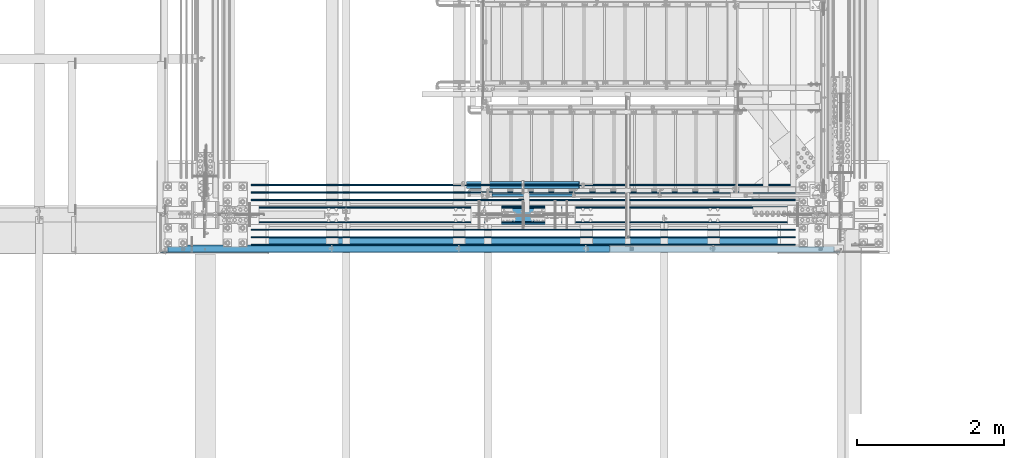
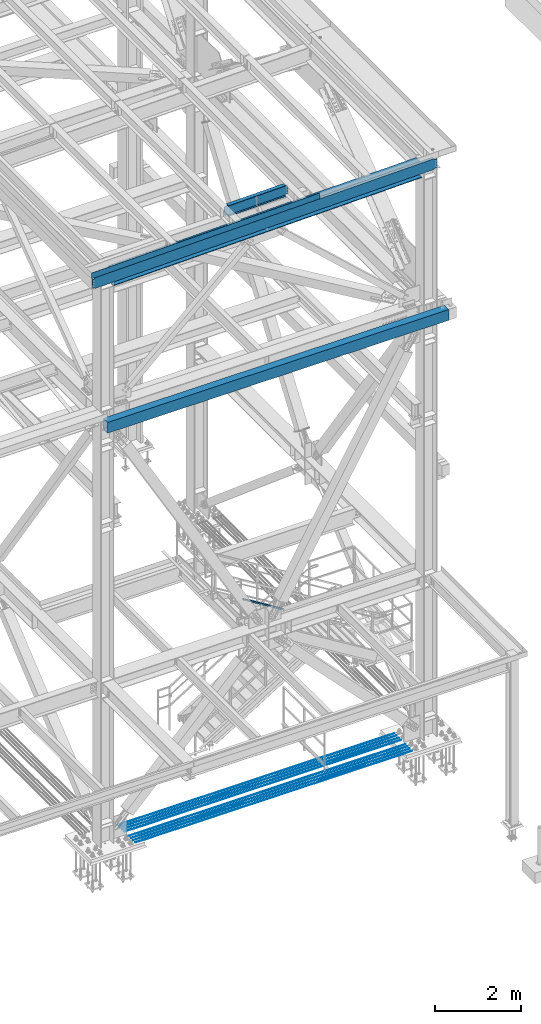
# One storey, part 1941 of 3843: 13 beams, 1 member, 13 elements without a shape of their own.
"""IFC2X3 building model written with IfcOpenShell, lengths in millimetres."""

from ifc_helpers import new_model, si_unit, frame, origin_with_axes, place, context, subcontext, project, spatial, faceted_brep, material, type_object, element, aggregate, save


model = new_model("IFC2X3")

# Units and contexts
model_context = context("Model", 3, precision=1e-05, world=origin_with_axes())
body_context = subcontext(model_context, "Body", "Model", "MODEL_VIEW")
ifc_project = project(units=[si_unit("LENGTHUNIT", "METRE", prefix="MILLI"), si_unit("AREAUNIT", "SQUARE_METRE"), si_unit("VOLUMEUNIT", "CUBIC_METRE"), si_unit("MASSUNIT", "GRAM", prefix="KILO"), si_unit("TIMEUNIT", "SECOND"), si_unit("PLANEANGLEUNIT", "RADIAN"), si_unit("SOLIDANGLEUNIT", "STERADIAN"), si_unit("THERMODYNAMICTEMPERATUREUNIT", "DEGREE_CELSIUS"), si_unit("LUMINOUSINTENSITYUNIT", "LUMEN")], contexts=[model_context])

# Site, building, storey
site_placement = place(None, origin_with_axes())
site = spatial("IfcSite", under=ifc_project, at=site_placement, CompositionType="ELEMENT")
building_placement = place(site_placement, origin_with_axes())
building = spatial("IfcBuilding", under=site, at=building_placement, Name="Undefined", CompositionType="ELEMENT")
storey_placement = place(building_placement, origin_with_axes())
storey = spatial("IfcBuildingStorey", under=building, at=storey_placement, Name="Undefined", CompositionType="ELEMENT", Elevation=0.0)

# Assembly, member
assembly_1_placement = place(storey_placement, origin_with_axes())
assembly_1 = element("IfcElementAssembly", 1, at=assembly_1_placement, inside=storey, Name="RAIL", AssemblyPlace="NOTDEFINED", PredefinedType="RIGID_FRAME")
ifc_material_1 = material()
member_type = type_object("IfcMemberType", Name="HSS1-1/2X1-1/2X1/4", PredefinedType="NOTDEFINED")
member_placement = place(assembly_1_placement, frame((82016.6000000184, 15265.4, 34796.0461536349), z_axis=(0.524097425775922, 0.0, 0.851658316635875), x_axis=(-0.851658316635873, 0.0, 0.524097425775925)))
member = element("IfcMember", 2, at=member_placement, type_object=member_type, material=ifc_material_1, Name="RAIL", ObjectType="HSS1-1/2X1-1/2X1/4", context=body_context, shape_type="Brep", body=[
    faceted_brep([(14.5527402998268, 12.6999993300014, -12.6999993299833), (14.5527402998268, -12.6999993300014, -12.6999993299833), (1308.66871958042, -12.6999993299996, -12.6999993292702), (1308.66871958042, 12.6999993299996, -12.6999993292702), (30.1835087105574, -12.6999993300014, 12.6999993299978), (1315.85799084432, -12.6999993299996, 12.6999993306963), (30.1835087105574, 12.6999993300014, 12.6999993299978), (1315.85799084432, 12.6999993299996, 12.6999993306963), (10.6450480494532, 19.0499992350015, -19.0499992349796), (34.091200960931, 19.0499992350015, 19.0499992349942), (1317.65530872822, 19.0499992349996, 19.0499992356781), (1306.87140169651, 19.0499992349996, -19.0499992342811), (34.091200960931, -19.0499992350015, 19.0499992349942), (1317.65530872822, -19.0499992349996, 19.0499992356781), (10.6450480494532, -19.0499992350015, -19.0499992349796), (1306.87140169651, -19.0499992349996, -19.0499992342811)], [[[0, 1, 2, 3]], [[1, 4, 5, 2]], [[4, 6, 7, 5]], [[6, 0, 3, 7]], [[8, 9, 10, 11]], [[9, 12, 13, 10]], [[12, 14, 15, 13]], [[14, 8, 11, 15]], [[13, 15, 11, 10], [5, 7, 3, 2]], [[14, 12, 9, 8], [6, 4, 1, 0]]]),
])
aggregate(assembly_1, [member])

# Assembly, beam
assembly_2_placement = place(storey_placement, origin_with_axes())
assembly_2 = element("IfcElementAssembly", 3, at=assembly_2_placement, inside=storey, Name="BEAM", AssemblyPlace="NOTDEFINED", PredefinedType="RIGID_FRAME")
ifc_material_2 = material(Name="STEEL/A572-50")
beam_type_1 = type_object("IfcBeamType", Name="C12X20.7", PredefinedType="NOTDEFINED")
beam_1_placement = place(assembly_2_placement, frame((76406.4235796702, 14528.8, 46419.8460854509), z_axis=(0.0211520550054438, 0.0, -0.999776270257025), x_axis=(0.999776270257024, 0.0, 0.0211520550054619)))
beam_1 = element("IfcBeam", 4, at=beam_1_placement, type_object=beam_type_1, material=ifc_material_2, Name="BEAM", ObjectType="C12X20.7", context=body_context, shape_type="Brep", body=[
    faceted_brep([(20.6374999136679, 30.1625000000058, -126.999999999352), (20.6374999136679, 38.1000000000058, -126.999999999352), (77.7875001037028, 38.1000000000058, -126.999999999302), (77.7875001037028, 30.1625000000058, -126.999999999302), (82.6475796217346, 38.1000000000058, -127.966729921885), (82.6475796217346, 30.1625000000058, -127.966729921885), (86.7677560898665, 38.1000000000058, -130.719743822337), (86.7677560898665, 30.1625000000058, -130.719743822337), (89.5207699903331, 38.1000000000058, -134.839920290469), (89.5207699903403, 30.1625000000058, -134.674927499684), (90.4874999129242, 1.14757858682424e-06, -139.699999808494), (90.4874999129242, 38.1000000000058, -139.699999808494), (90.4874999129315, 38.1000000000058, -152.399999999659), (90.4874999129388, -38.1000000000058, -152.39999980729), (90.4874999129315, -38.1000000000058, -146.047459999667), (9149.24043571523, -38.1000000000058, 146.047460007532), (9149.24043571524, -38.1000000000058, 152.400000007532), (90.4874999126405, -38.1000000000058, 152.39999980975), (90.4874999126478, -38.1000000000058, 146.047459999863), (9149.24043571524, 38.1000000000058, 152.400000007532), (90.4874999126478, 38.1000000000058, 152.399999999849), (77.7875001034699, 30.1625000000058, 126.999999999338), (77.7875001034699, 38.1000000000058, 126.999999999338), (20.6374999136751, 38.1000000000058, 126.999999999272), (20.6374999136751, 30.1625000000058, 126.999999999272), (82.6475796214872, 30.1625000000058, 127.966729921922), (82.6475796214872, 38.1000000000058, 127.966729921922), (86.7677560896191, 30.1625000000058, 130.719743822396), (86.7677560896191, 38.1000000000058, 130.719743822396), (89.5207699900784, 30.1625000000058, 134.674927499873), (89.5207699900784, 38.1000000000058, 134.839920290535), (90.487499912655, 1.14834983833134e-06, 139.699999808552), (90.487499912655, 38.1000000000058, 139.699999808552), (9150.20716563785, 30.1625000000058, 134.674927507556), (9149.24043571524, 2.60435626842082e-07, 139.699999964156), (9149.24043571524, 38.1000000000058, 139.699999964156), (9150.20716563787, 38.1000000000058, 134.839920446146), (9152.96017953839, 30.1625000000058, 130.719743978014), (9152.96017953839, 38.1000000000058, 130.719743978014), (9157.08035600661, 30.1625000000058, 127.966730077547), (9157.08035600661, 38.1000000000058, 127.966730077547), (9161.94043552474, 30.1625000000058, 127.000000154971), (9161.94043552474, 38.1000000000058, 127.000000154971), (9225.87921576094, 30.1625000000004, 127.000000654043), (9225.87921576094, 38.1000000000004, 127.000000654043), (9226.09229656124, 30.1625000000004, 116.928510933074), (9230.96997013122, 30.1625000000004, -113.619896782788), (9231.25305069239, 30.1625000000004, -126.999999345084), (9231.25305069239, 38.1000000000004, -126.999999345084), (9161.94043551943, 30.1625000000058, -126.999999844498), (9161.94043551943, 38.1000000000058, -126.999999844498), (9157.0803560013, 30.1625000000058, -127.966729767082), (9157.0803560013, 38.1000000000058, -127.966729767082), (9152.96017953308, 30.1625000000058, -130.719743667549), (9152.96017953308, 38.1000000000058, -130.719743667549), (9150.20716563256, 30.1625000000058, -134.674927492008), (9150.20716563256, 38.1000000000058, -134.839920135695), (9149.24043570996, 2.03055969905108e-06, -139.699999653712), (9149.24043570996, 38.1000000000058, -139.699999653712), (9149.24043570996, -38.1000000000058, -146.047459991983), (9149.24043570994, -38.1000000000058, -152.399999991976), (9149.24043570994, 38.1000000000058, -152.399999991976), (20.6374999295222, 30.1625000000004, -114.29999996836), (20.6375001600682, 30.1625000000004, 116.300000028175)], [[[0, 1, 2, 3]], [[3, 2, 4, 5]], [[5, 4, 6, 7]], [[7, 6, 8, 9]], [[10, 11, 12, 13, 14]], [[9, 8, 11, 10]], [[15, 16, 17, 18]], [[16, 19, 20, 17]], [[21, 22, 23, 24]], [[25, 26, 22, 21]], [[27, 28, 26, 25]], [[29, 30, 28, 27]], [[31, 32, 30, 29]], [[17, 20, 32, 31, 18]], [[29, 33, 34, 15, 18, 31]], [[16, 15, 34, 35, 19]], [[33, 36, 35, 34]], [[37, 38, 36, 33]], [[39, 40, 38, 37]], [[41, 42, 40, 39]], [[43, 44, 42, 41]], [[44, 43, 45, 46, 47, 48]], [[47, 49, 50, 48]], [[51, 52, 50, 49]], [[53, 54, 52, 51]], [[55, 56, 54, 53]], [[57, 58, 56, 55]], [[59, 60, 61, 58, 57]], [[60, 59, 14, 13]], [[61, 60, 13, 12]], [[6, 4, 2, 1, 23, 22, 26, 28, 30, 32, 20, 19, 35, 36, 38, 40, 42, 44, 48, 50, 52, 54, 56, 58, 61, 12, 11, 8]], [[62, 63, 24, 23, 1, 0]], [[55, 53, 51, 49, 47, 46, 45, 43, 41, 39, 37, 33, 29, 27, 25, 21, 24, 63, 62, 0, 3, 5, 7, 9]], [[59, 57, 55, 9, 10, 14]]]),
])

assembly_3_placement = place(storey_placement, origin_with_axes())
assembly_3 = element("IfcElementAssembly", 5, at=assembly_3_placement, inside=storey, Name="REBAR", AssemblyPlace="NOTDEFINED", PredefinedType="RIGID_FRAME")
ifc_material_3 = material(Name="STEEL/A706-60")
beam_type_2 = type_object("IfcBeamType", Name="#10 REBAR", PredefinedType="NOTDEFINED")
beam_2_placement = place(assembly_3_placement, frame((85026.5, 14693.9, 30157.7375), z_axis=(0.0, 0.0, 1.0), x_axis=(-1.0, 0.0, 0.0)))
beam_2 = element("IfcBeam", 6, at=beam_2_placement, type_object=beam_type_2, material=ifc_material_3, Name="REBAR", ObjectType="#10 REBAR", context=body_context, shape_type="Brep", body=[
    faceted_brep([(0.0, -7.9375, 0.0), (0.0, -5.61266007566883, -5.61266007566883), (7391.39995117186, -5.61266007566883, -5.61266007566883), (7391.39995117186, -7.9375, 0.0), (0.0, 0.0, -7.9375), (7391.39995117186, 0.0, -7.9375), (0.0, 5.61266007566883, -5.61266007566883), (7391.39995117186, 5.61266007566883, -5.61266007566883), (0.0, 7.9375, 0.0), (7391.39995117186, 7.9375, 0.0), (0.0, 5.61266007566883, 5.61266007566883), (7391.39995117186, 5.61266007566883, 5.61266007566883), (0.0, 0.0, 7.9375), (7391.39995117186, 0.0, 7.9375), (0.0, -5.61266007566883, 5.61266007566883), (7391.39995117186, -5.61266007566883, 5.61266007566883)], [[[0, 1, 2, 3]], [[1, 4, 5, 2]], [[4, 6, 7, 5]], [[6, 8, 9, 7]], [[8, 10, 11, 9]], [[10, 12, 13, 11]], [[12, 14, 15, 13]], [[14, 0, 3, 15]], [[5, 7, 9, 11, 13, 15, 3, 2]], [[14, 12, 10, 8, 6, 4, 1, 0]]]),
])
aggregate(assembly_3, [beam_2])

assembly_4_placement = place(storey_placement, origin_with_axes())
assembly_4 = element("IfcElementAssembly", 7, at=assembly_4_placement, inside=storey, Name="REBAR", AssemblyPlace="NOTDEFINED", PredefinedType="RIGID_FRAME")
beam_3_placement = place(assembly_4_placement, frame((85026.5, 14592.3, 30157.7375), z_axis=(0.0, 0.0, 1.0), x_axis=(-1.0, 0.0, 0.0)))
beam_3 = element("IfcBeam", 8, at=beam_3_placement, type_object=beam_type_2, material=ifc_material_3, Name="REBAR", ObjectType="#10 REBAR", context=body_context, shape_type="Brep", body=[
    faceted_brep([(0.0, -7.9375, 0.0), (0.0, -5.61266007566883, -5.61266007566883), (7391.39995117186, -5.61266007566883, -5.61266007566883), (7391.39995117186, -7.9375, 0.0), (0.0, 0.0, -7.9375), (7391.39995117186, 0.0, -7.9375), (0.0, 5.61266007566883, -5.61266007566883), (7391.39995117186, 5.61266007566883, -5.61266007566883), (0.0, 7.9375, 0.0), (7391.39995117186, 7.9375, 0.0), (0.0, 5.61266007566883, 5.61266007566883), (7391.39995117186, 5.61266007566883, 5.61266007566883), (0.0, 0.0, 7.9375), (7391.39995117186, 0.0, 7.9375), (0.0, -5.61266007566883, 5.61266007566883), (7391.39995117186, -5.61266007566883, 5.61266007566883)], [[[0, 1, 2, 3]], [[1, 4, 5, 2]], [[4, 6, 7, 5]], [[6, 8, 9, 7]], [[8, 10, 11, 9]], [[10, 12, 13, 11]], [[12, 14, 15, 13]], [[14, 0, 3, 15]], [[5, 7, 9, 11, 13, 15, 3, 2]], [[14, 12, 10, 8, 6, 4, 1, 0]]]),
])
aggregate(assembly_4, [beam_3])

assembly_5_placement = place(storey_placement, origin_with_axes())
assembly_5 = element("IfcElementAssembly", 9, at=assembly_5_placement, inside=storey, Name="REBAR", AssemblyPlace="NOTDEFINED", PredefinedType="RIGID_FRAME")
beam_4_placement = place(assembly_5_placement, frame((85026.5, 15405.1, 30157.7375), z_axis=(0.0, 0.0, 1.0), x_axis=(-1.0, 0.0, 0.0)))
beam_4 = element("IfcBeam", 10, at=beam_4_placement, type_object=beam_type_2, material=ifc_material_3, Name="REBAR", ObjectType="#10 REBAR", context=body_context, shape_type="Brep", body=[
    faceted_brep([(0.0, -7.9375, 0.0), (0.0, -5.61266007566883, -5.61266007566883), (7391.39995117186, -5.61266007566883, -5.61266007566883), (7391.39995117186, -7.9375, 0.0), (0.0, 0.0, -7.9375), (7391.39995117186, 0.0, -7.9375), (0.0, 5.61266007566883, -5.61266007566883), (7391.39995117186, 5.61266007566883, -5.61266007566883), (0.0, 7.9375, 0.0), (7391.39995117186, 7.9375, 0.0), (0.0, 5.61266007566883, 5.61266007566883), (7391.39995117186, 5.61266007566883, 5.61266007566883), (0.0, 0.0, 7.9375), (7391.39995117186, 0.0, 7.9375), (0.0, -5.61266007566883, 5.61266007566883), (7391.39995117186, -5.61266007566883, 5.61266007566883)], [[[0, 1, 2, 3]], [[1, 4, 5, 2]], [[4, 6, 7, 5]], [[6, 8, 9, 7]], [[8, 10, 11, 9]], [[10, 12, 13, 11]], [[12, 14, 15, 13]], [[14, 0, 3, 15]], [[5, 7, 9, 11, 13, 15, 3, 2]], [[14, 12, 10, 8, 6, 4, 1, 0]]]),
])
aggregate(assembly_5, [beam_4])

assembly_6_placement = place(storey_placement, origin_with_axes())
assembly_6 = element("IfcElementAssembly", 11, at=assembly_6_placement, inside=storey, Name="REBAR", AssemblyPlace="NOTDEFINED", PredefinedType="RIGID_FRAME")
beam_5_placement = place(assembly_6_placement, frame((85026.5, 15303.5, 30157.7375), z_axis=(0.0, 0.0, 1.0), x_axis=(-1.0, 0.0, 0.0)))
beam_5 = element("IfcBeam", 12, at=beam_5_placement, type_object=beam_type_2, material=ifc_material_3, Name="REBAR", ObjectType="#10 REBAR", context=body_context, shape_type="Brep", body=[
    faceted_brep([(0.0, -7.9375, 0.0), (0.0, -5.61266007566883, -5.61266007566883), (7391.39995117186, -5.61266007566883, -5.61266007566883), (7391.39995117186, -7.9375, 0.0), (0.0, 0.0, -7.9375), (7391.39995117186, 0.0, -7.9375), (0.0, 5.61266007566883, -5.61266007566883), (7391.39995117186, 5.61266007566883, -5.61266007566883), (0.0, 7.9375, 0.0), (7391.39995117186, 7.9375, 0.0), (0.0, 5.61266007566883, 5.61266007566883), (7391.39995117186, 5.61266007566883, 5.61266007566883), (0.0, 0.0, 7.9375), (7391.39995117186, 0.0, 7.9375), (0.0, -5.61266007566883, 5.61266007566883), (7391.39995117186, -5.61266007566883, 5.61266007566883)], [[[0, 1, 2, 3]], [[1, 4, 5, 2]], [[4, 6, 7, 5]], [[6, 8, 9, 7]], [[8, 10, 11, 9]], [[10, 12, 13, 11]], [[12, 14, 15, 13]], [[14, 0, 3, 15]], [[5, 7, 9, 11, 13, 15, 3, 2]], [[14, 12, 10, 8, 6, 4, 1, 0]]]),
])
aggregate(assembly_6, [beam_5])

assembly_7_placement = place(storey_placement, origin_with_axes())
assembly_7 = element("IfcElementAssembly", 13, at=assembly_7_placement, inside=storey, Name="REBAR", AssemblyPlace="NOTDEFINED", PredefinedType="RIGID_FRAME")
beam_6_placement = place(assembly_7_placement, frame((85026.5, 15201.9, 30157.7375), z_axis=(0.0, 0.0, 1.0), x_axis=(-1.0, 0.0, 0.0)))
beam_6 = element("IfcBeam", 14, at=beam_6_placement, type_object=beam_type_2, material=ifc_material_3, Name="REBAR", ObjectType="#10 REBAR", context=body_context, shape_type="Brep", body=[
    faceted_brep([(0.0, -7.9375, 0.0), (0.0, -5.61266007566883, -5.61266007566883), (7391.39995117186, -5.61266007566883, -5.61266007566883), (7391.39995117186, -7.9375, 0.0), (0.0, 0.0, -7.9375), (7391.39995117186, 0.0, -7.9375), (0.0, 5.61266007566883, -5.61266007566883), (7391.39995117186, 5.61266007566883, -5.61266007566883), (0.0, 7.9375, 0.0), (7391.39995117186, 7.9375, 0.0), (0.0, 5.61266007566883, 5.61266007566883), (7391.39995117186, 5.61266007566883, 5.61266007566883), (0.0, 0.0, 7.9375), (7391.39995117186, 0.0, 7.9375), (0.0, -5.61266007566883, 5.61266007566883), (7391.39995117186, -5.61266007566883, 5.61266007566883)], [[[0, 1, 2, 3]], [[1, 4, 5, 2]], [[4, 6, 7, 5]], [[6, 8, 9, 7]], [[8, 10, 11, 9]], [[10, 12, 13, 11]], [[12, 14, 15, 13]], [[14, 0, 3, 15]], [[5, 7, 9, 11, 13, 15, 3, 2]], [[14, 12, 10, 8, 6, 4, 1, 0]]]),
])
aggregate(assembly_7, [beam_6])

assembly_8_placement = place(storey_placement, origin_with_axes())
assembly_8 = element("IfcElementAssembly", 15, at=assembly_8_placement, inside=storey, Name="REBAR", AssemblyPlace="NOTDEFINED", PredefinedType="RIGID_FRAME")
beam_7_placement = place(assembly_8_placement, frame((85026.5, 15100.3, 30157.7375), z_axis=(0.0, 0.0, 1.0), x_axis=(-1.0, 0.0, 0.0)))
beam_7 = element("IfcBeam", 16, at=beam_7_placement, type_object=beam_type_2, material=ifc_material_3, Name="REBAR", ObjectType="#10 REBAR", context=body_context, shape_type="Brep", body=[
    faceted_brep([(0.0, -7.9375, 0.0), (0.0, -5.61266007566883, -5.61266007566883), (7391.39995117186, -5.61266007566883, -5.61266007566883), (7391.39995117186, -7.9375, 0.0), (0.0, 0.0, -7.9375), (7391.39995117186, 0.0, -7.9375), (0.0, 5.61266007566883, -5.61266007566883), (7391.39995117186, 5.61266007566883, -5.61266007566883), (0.0, 7.9375, 0.0), (7391.39995117186, 7.9375, 0.0), (0.0, 5.61266007566883, 5.61266007566883), (7391.39995117186, 5.61266007566883, 5.61266007566883), (0.0, 0.0, 7.9375), (7391.39995117186, 0.0, 7.9375), (0.0, -5.61266007566883, 5.61266007566883), (7391.39995117186, -5.61266007566883, 5.61266007566883)], [[[0, 1, 2, 3]], [[1, 4, 5, 2]], [[4, 6, 7, 5]], [[6, 8, 9, 7]], [[8, 10, 11, 9]], [[10, 12, 13, 11]], [[12, 14, 15, 13]], [[14, 0, 3, 15]], [[5, 7, 9, 11, 13, 15, 3, 2]], [[14, 12, 10, 8, 6, 4, 1, 0]]]),
])
aggregate(assembly_8, [beam_7])

assembly_9_placement = place(storey_placement, origin_with_axes())
assembly_9 = element("IfcElementAssembly", 17, at=assembly_9_placement, inside=storey, Name="REBAR", AssemblyPlace="NOTDEFINED", PredefinedType="RIGID_FRAME")
beam_8_placement = place(assembly_9_placement, frame((85026.5, 14897.1, 30157.7375), z_axis=(0.0, 0.0, 1.0), x_axis=(-1.0, 0.0, 0.0)))
beam_8 = element("IfcBeam", 18, at=beam_8_placement, type_object=beam_type_2, material=ifc_material_3, Name="REBAR", ObjectType="#10 REBAR", context=body_context, shape_type="Brep", body=[
    faceted_brep([(0.0, -7.9375, 0.0), (0.0, -5.61266007566883, -5.61266007566883), (7391.39995117186, -5.61266007566883, -5.61266007566883), (7391.39995117186, -7.9375, 0.0), (0.0, 0.0, -7.9375), (7391.39995117186, 0.0, -7.9375), (0.0, 5.61266007566883, -5.61266007566883), (7391.39995117186, 5.61266007566883, -5.61266007566883), (0.0, 7.9375, 0.0), (7391.39995117186, 7.9375, 0.0), (0.0, 5.61266007566883, 5.61266007566883), (7391.39995117186, 5.61266007566883, 5.61266007566883), (0.0, 0.0, 7.9375), (7391.39995117186, 0.0, 7.9375), (0.0, -5.61266007566883, 5.61266007566883), (7391.39995117186, -5.61266007566883, 5.61266007566883)], [[[0, 1, 2, 3]], [[1, 4, 5, 2]], [[4, 6, 7, 5]], [[6, 8, 9, 7]], [[8, 10, 11, 9]], [[10, 12, 13, 11]], [[12, 14, 15, 13]], [[14, 0, 3, 15]], [[5, 7, 9, 11, 13, 15, 3, 2]], [[14, 12, 10, 8, 6, 4, 1, 0]]]),
])
aggregate(assembly_9, [beam_8])

assembly_10_placement = place(storey_placement, origin_with_axes())
assembly_10 = element("IfcElementAssembly", 19, at=assembly_10_placement, inside=storey, Name="REBAR", AssemblyPlace="NOTDEFINED", PredefinedType="RIGID_FRAME")
beam_9_placement = place(assembly_10_placement, frame((85026.5, 14795.5, 30157.7375), z_axis=(0.0, 0.0, 1.0), x_axis=(-1.0, 0.0, 0.0)))
beam_9 = element("IfcBeam", 20, at=beam_9_placement, type_object=beam_type_2, material=ifc_material_3, Name="REBAR", ObjectType="#10 REBAR", context=body_context, shape_type="Brep", body=[
    faceted_brep([(0.0, -7.9375, 0.0), (0.0, -5.61266007566883, -5.61266007566883), (7391.39995117186, -5.61266007566883, -5.61266007566883), (7391.39995117186, -7.9375, 0.0), (0.0, 0.0, -7.9375), (7391.39995117186, 0.0, -7.9375), (0.0, 5.61266007566883, -5.61266007566883), (7391.39995117186, 5.61266007566883, -5.61266007566883), (0.0, 7.9375, 0.0), (7391.39995117186, 7.9375, 0.0), (0.0, 5.61266007566883, 5.61266007566883), (7391.39995117186, 5.61266007566883, 5.61266007566883), (0.0, 0.0, 7.9375), (7391.39995117186, 0.0, 7.9375), (0.0, -5.61266007566883, 5.61266007566883), (7391.39995117186, -5.61266007566883, 5.61266007566883)], [[[0, 1, 2, 3]], [[1, 4, 5, 2]], [[4, 6, 7, 5]], [[6, 8, 9, 7]], [[8, 10, 11, 9]], [[10, 12, 13, 11]], [[12, 14, 15, 13]], [[14, 0, 3, 15]], [[5, 7, 9, 11, 13, 15, 3, 2]], [[14, 12, 10, 8, 6, 4, 1, 0]]]),
])
aggregate(assembly_10, [beam_9])

# Beam
ifc_material_4 = material(Name="STEEL/A36")
beam_type_3 = type_object("IfcBeamType", PredefinedType="NOTDEFINED")
beam_10_placement = place(assembly_2_placement, frame((79456.7994940137, 14592.2999962681, 46639.9921864517), z_axis=(0.999776270257024, 0.0, 0.0211520550054619), x_axis=(0.0, -1.0, 0.0)))
beam_10 = element("IfcBeam", 21, at=beam_10_placement, type_object=beam_type_3, material=ifc_material_4, Name="BENT_PLATE", context=body_context, shape_type="Brep", body=[
    faceted_brep([(101.599999230692, -3.17499999520078, -2952.75000752405), (95.2499993285855, -3.17499999603751, -2952.75000753038), (-6.95581547915936e-09, -3.17499999749998, -2952.75000762529), (-7.04676494933665e-09, 3.17500000249856, -2952.75000762529), (101.599999328762, 3.17500000404834, -2952.75000752405), (101.59999932838, -3.17499999513529, -3048.00000001783), (95.249998765099, -3.17499999632128, -3048.00000002851), (95.2500003092064, -161.925000900388, 3047.99999999456), (95.2499996083752, -161.925000471427, -3048.00000003992), (101.599999608374, -161.925000446165, -3048.00000004067), (101.600000309205, -161.925000875126, 3047.9999999938), (101.599999864371, 3.17499999856227, 3048.00000000522), (3.5035191103816e-07, 3.17499999739084, 3048.00000001724), (3.50421032635495e-07, -3.17500000260043, 3048.00000001724), (95.2499998896274, -3.17500000149448, 3048.00000000597)], [[[0, 1, 2, 3, 4]], [[5, 6, 1, 0]], [[7, 8, 9, 10]], [[11, 12, 13, 14, 7, 10]], [[12, 11, 4, 3]], [[13, 12, 3, 2]], [[14, 13, 2, 1]], [[8, 7, 14, 1, 6]], [[9, 8, 6, 5]], [[11, 10, 9, 5, 0, 4]]]),
])

aggregate(assembly_2, [beam_1, beam_10])

# Assembly, beam
assembly_11_placement = place(storey_placement, origin_with_axes())
assembly_11 = element("IfcElementAssembly", 22, at=assembly_11_placement, inside=storey, Name="GIRT", AssemblyPlace="NOTDEFINED", PredefinedType="RIGID_FRAME")
ifc_material_5 = material()
beam_type_4 = type_object("IfcBeamType", Name="HSS12X8X3/8", PredefinedType="NOTDEFINED")
beam_11_placement = place(assembly_11_placement, frame((76828.65, 14592.3, 42214.8000000001), z_axis=(0.0, 0.0, 1.0), x_axis=(1.0, 0.0, 0.0)))
beam_11 = element("IfcBeam", 23, at=beam_11_placement, type_object=beam_type_4, material=ifc_material_5, Name="GIRT", ObjectType="HSS12X8X3/8", context=body_context, shape_type="Brep", body=[
    faceted_brep([(6.35000000002037, 92.0749999999971, -142.875), (6.35000000002037, -92.0749999999971, -142.875), (9123.36299998758, -92.0750000000007, -142.875), (9123.36299998758, 92.0750000000007, -142.875), (6.35000000002037, -92.0749999999971, 142.875), (9123.36299998758, -92.0750000000007, 142.875), (6.35000000002037, 92.0749999999971, 142.875), (9123.36299998758, 92.0750000000007, 142.875), (6.35000000002037, 101.600000000006, -152.400000000001), (6.35000000002037, 101.600000000006, 152.400000000001), (9123.36299998758, 101.6, 152.400000000001), (9123.36299998758, 101.6, -152.400000000001), (6.35000000002037, -101.600000000006, 152.400000000001), (9123.36299998758, -101.6, 152.400000000001), (6.35000000002037, -101.600000000006, -152.400000000001), (9123.36299998758, -101.6, -152.400000000001)], [[[0, 1, 2, 3]], [[1, 4, 5, 2]], [[4, 6, 7, 5]], [[6, 0, 3, 7]], [[8, 9, 10, 11]], [[9, 12, 13, 10]], [[12, 14, 15, 13]], [[14, 8, 11, 15]], [[13, 15, 11, 10], [5, 7, 3, 2]], [[14, 12, 9, 8], [6, 4, 1, 0]]]),
])
aggregate(assembly_11, [beam_11])

assembly_12_placement = place(storey_placement, origin_with_axes())
assembly_12 = element("IfcElementAssembly", 24, at=assembly_12_placement, inside=storey, Name="BEAM", AssemblyPlace="NOTDEFINED", PredefinedType="RIGID_FRAME")
ifc_material_6 = material(Name="STEEL/A992")
beam_type_5 = type_object("IfcBeamType", Name="W12X19", PredefinedType="NOTDEFINED")
beam_12_placement = place(assembly_12_placement, frame((80463.8756837405, 15405.1, 46504.1010604393), z_axis=(-0.0211520980073474, 0.0, 0.999776269347241), x_axis=(0.999776270257024, 0.0, 0.0211520550054619)))
beam_12 = element("IfcBeam", 25, at=beam_12_placement, type_object=beam_type_5, material=ifc_material_6, Name="BEAM", ObjectType="W12X19", context=body_context, shape_type="Brep", body=[
    faceted_brep([(15.8750000000146, -3.17500000000291, -128.587499998961), (15.8750000000146, 3.17500000000291, -128.587499998961), (85.7250002643268, 3.17500000000291, -128.587499999245), (85.7250002643268, -3.17500000000291, -128.587499999245), (90.5850797824532, 3.17500000000291, -129.554229921821), (90.5850797824532, -3.17500000000291, -129.554229921821), (94.7052562506724, 3.17500000000291, -132.307243822288), (94.7052562506724, -3.17500000000291, -132.307243822288), (97.4582701512118, 3.17500000000291, -136.42742029042), (97.4582701512118, -3.17500000000291, -136.42742029042), (98.4250000738248, -3.17500000000291, -141.287499808437), (98.4250000738248, 3.17500000000291, -141.287499808437), (98.4250000738248, 3.17500000000291, -144.462499999689), (98.4250000738248, 50.8000000000029, -144.462499999689), (98.4250000738248, 50.8000000000029, -153.987499999661), (98.4250000738248, -50.8000000000029, -153.987499999661), (98.4250000738248, -50.8000000000029, -144.462499999689), (98.4250000738248, -3.17500000000291, -144.462499999689), (1629.16151416571, 50.8000000000029, 144.462500001144), (1629.16151416571, 3.17500000000291, 144.462500001144), (98.4250000735046, 3.17500000000291, 144.462499999849), (98.4250000735046, 50.8000000000029, 144.462499999849), (85.7250002640503, -3.17500000000291, 128.587499999507), (85.7250002640503, 3.17500000000291, 128.587499999507), (15.8750000000146, 3.17500000000291, 128.587500001042), (15.8750000000146, -3.17500000000291, 128.587500001042), (90.5850797821768, -3.17500000000291, 129.554229922083), (90.5850797821768, 3.17500000000291, 129.554229922083), (94.7052562504105, -3.17500000000291, 132.30724382255), (94.7052562504105, 3.17500000000291, 132.30724382255), (97.4582701509353, -3.17500000000291, 136.427420290682), (97.4582701509353, 3.17500000000291, 136.427420290682), (98.4250000735192, -3.17500000000291, 141.287499808706), (98.4250000735192, 3.17500000000291, 141.287499808706), (1629.16151416571, -50.8000000000029, 153.987500001138), (1629.16151416571, 50.8000000000029, 153.987500001138), (98.4250000735046, 50.8000000000029, 153.987499999828), (98.4250000735046, -50.8000000000029, 153.987499999828), (1629.16151416571, -50.8000000000029, 144.462500001144), (98.4250000735046, -50.8000000000029, 144.462499999849), (1629.16151416571, -3.17500000000291, 144.462500001144), (98.4250000735046, -3.17500000000291, 144.462499999849), (1629.16151416574, -3.17500000000291, 141.287499824422), (1629.16151416574, 3.17500000000291, 141.287499824422), (1630.12824408834, -3.17500000000291, 136.427420306398), (1630.12824408834, 3.17500000000291, 136.427420306398), (1632.88125798886, -3.17500000000291, 132.307243838266), (1632.88125798886, 3.17500000000291, 132.307243838266), (1637.0014344571, -3.17500000000291, 129.554229937807), (1637.0014344571, 3.17500000000291, 129.554229937807), (1641.86151397521, -3.17500000000291, 128.58750001523), (1641.86151397521, 3.17500000000291, 128.58750001523), (1711.71151414872, -3.17500000000291, 128.587500015296), (1711.71151414872, 3.17500000000291, 128.587500015296), (1711.71151414876, 3.17500000000291, -114.712499998575), (1711.71151414873, 3.17500000000291, 115.887499997691), (1711.71151414874, -3.17500000000291, -128.587499983507), (1711.71151414874, 3.17500000000291, -128.587499983507), (1641.86151397551, -3.17500000000291, -128.587499983521), (1641.86151397551, 3.17500000000291, -128.587499983521), (1637.00143445739, -3.17500000000291, -129.554229906113), (1637.00143445739, 3.17500000000291, -129.554229906113), (1632.88125798917, -3.17500000000291, -132.307243806579), (1632.88125798917, 3.17500000000291, -132.307243806579), (1630.12824408866, -3.17500000000291, -136.427420274718), (1630.12824408866, 3.17500000000291, -136.427420274718), (1629.16151416604, -3.17500000000291, -141.287499792743), (1629.16151416604, 3.17500000000291, -141.287499792743), (1629.16151416604, -3.17500000000291, -144.462499998393), (1629.16151416604, -50.8000000000029, -144.462499998393), (1629.16151416606, -50.8000000000029, -153.987499998373), (1629.16151416606, 50.8000000000029, -153.987499998373), (1629.16151416604, 50.8000000000029, -144.462499998393), (1629.16151416604, 3.17500000000291, -144.462499998393), (15.8750000000146, 3.17500000000291, -114.712499998386), (15.8750000000146, 3.17500000000291, 115.887500001612)], [[[0, 1, 2, 3]], [[3, 2, 4, 5]], [[5, 4, 6, 7]], [[7, 6, 8, 9]], [[10, 11, 12, 13, 14, 15, 16, 17]], [[9, 8, 11, 10]], [[18, 19, 20, 21]], [[22, 23, 24, 25]], [[26, 27, 23, 22]], [[28, 29, 27, 26]], [[30, 31, 29, 28]], [[32, 33, 31, 30]], [[34, 35, 36, 37]], [[38, 34, 37, 39]], [[40, 38, 39, 41]], [[37, 36, 21, 20, 33, 32, 41, 39]], [[35, 18, 21, 36]], [[34, 38, 40, 42, 43, 19, 18, 35]], [[44, 45, 43, 42]], [[46, 47, 45, 44]], [[48, 49, 47, 46]], [[50, 51, 49, 48]], [[52, 53, 51, 50]], [[54, 55, 53, 52, 56, 57]], [[56, 58, 59, 57]], [[60, 61, 59, 58]], [[62, 63, 61, 60]], [[64, 65, 63, 62]], [[66, 67, 65, 64]], [[68, 69, 70, 71, 72, 73, 67, 66]], [[69, 68, 17, 16]], [[70, 69, 16, 15]], [[71, 70, 15, 14]], [[72, 71, 14, 13]], [[73, 72, 13, 12]], [[6, 4, 2, 1, 74, 75, 24, 23, 27, 29, 31, 33, 20, 19, 43, 45, 47, 49, 51, 53, 55, 54, 57, 59, 61, 63, 65, 67, 73, 12, 11, 8]], [[25, 24, 75, 74, 1, 0]], [[68, 66, 64, 62, 60, 58, 56, 52, 50, 48, 46, 44, 42, 40, 41, 32, 30, 28, 26, 22, 25, 0, 3, 5, 7, 9, 10, 17]]]),
])
aggregate(assembly_12, [beam_12])

assembly_13_placement = place(storey_placement, origin_with_axes())
assembly_13 = element("IfcElementAssembly", 26, at=assembly_13_placement, inside=storey, Name="BEAM", AssemblyPlace="NOTDEFINED", PredefinedType="RIGID_FRAME")
beam_type_6 = type_object("IfcBeamType", Name="W16X67", PredefinedType="NOTDEFINED")
beam_13_placement = place(assembly_13_placement, frame((77017.1988428479, 14998.7, 46065.9736071223), z_axis=(-0.0211520980073474, 0.0, 0.999776269347241), x_axis=(0.999776270257024, 0.0, 0.0211520550054619)))
beam_13 = element("IfcBeam", 27, at=beam_13_placement, type_object=beam_type_6, material=ifc_material_6, Name="BEAM", ObjectType="W16X67", context=body_context, shape_type="Brep", body=[
    faceted_brep([(188.094396478875, -130.174999999999, -207.962499999492), (188.094396478875, 130.174999999999, -207.962499999492), (8432.23886485929, 130.174999999999, -207.962499992493), (8432.23886485929, -130.174999999999, -207.962499992493), (188.463847647872, -130.174999999999, -190.49999999952), (188.463847647872, -4.76250000000073, -190.49999999952), (196.524600426201, -4.76250000000073, 190.499999999869), (196.524600426201, -130.174999999999, 190.499999999869), (196.894051595213, -130.174999999999, 207.962499999841), (196.894051595213, 130.174999999999, 207.962499999841), (196.524600426201, 130.174999999999, 190.499999999869), (196.524600426201, 4.76250000000073, 190.499999999869), (188.463847647872, 4.76250000000073, -190.49999999952), (188.463847647872, 130.174999999999, -190.49999999952), (8432.60831602832, -130.174999999999, -190.49999999252), (8432.60831602832, -4.76250000000073, -190.49999999252), (8440.66906880663, -4.76250000000073, 190.500000006876), (8440.66906880663, -130.174999999999, 190.500000006876), (8441.03851997564, -130.174999999999, 207.962500006841), (8441.03851997564, 130.174999999999, 207.962500006841), (8440.66906880663, 130.174999999999, 190.500000006876), (8440.66906880663, 4.76250000000073, 190.500000006876), (8432.60831602832, 4.76250000000073, -190.49999999252), (8432.60831602832, 130.174999999999, -190.49999999252)], [[[0, 1, 2, 3]], [[0, 4, 5, 6, 7, 8, 9, 10, 11, 12, 13, 1]], [[5, 4, 14, 15]], [[6, 5, 15, 16]], [[7, 6, 16, 17]], [[8, 7, 17, 18]], [[9, 8, 18, 19]], [[10, 9, 19, 20]], [[11, 10, 20, 21]], [[12, 11, 21, 22]], [[13, 12, 22, 23]], [[1, 13, 23, 2]], [[22, 21, 20, 19, 18, 17, 16, 15, 14, 3, 2, 23]], [[4, 0, 3, 14]]]),
])
aggregate(assembly_13, [beam_13])

save(model, "model.ifc")
